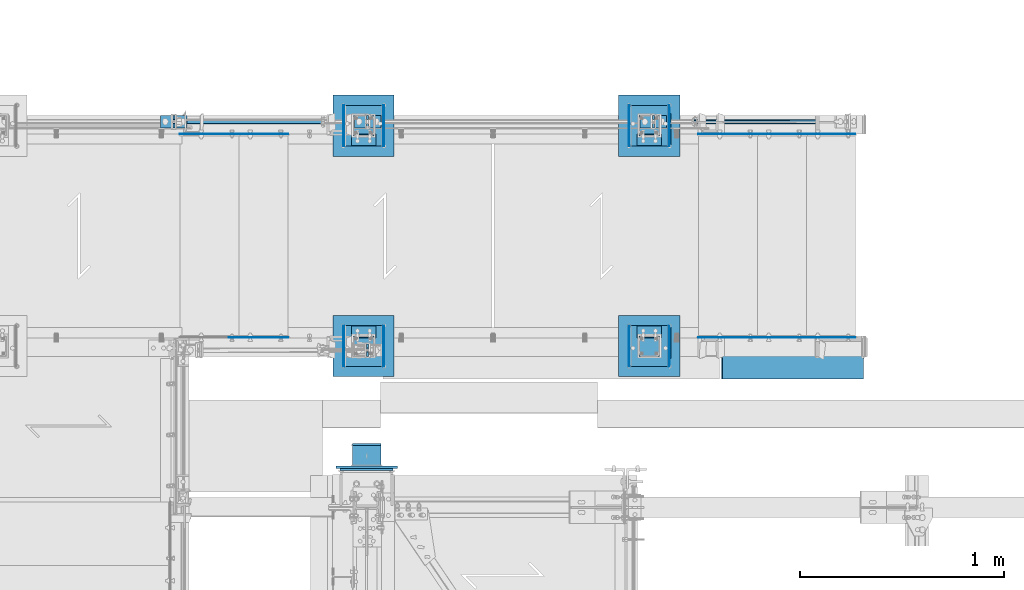
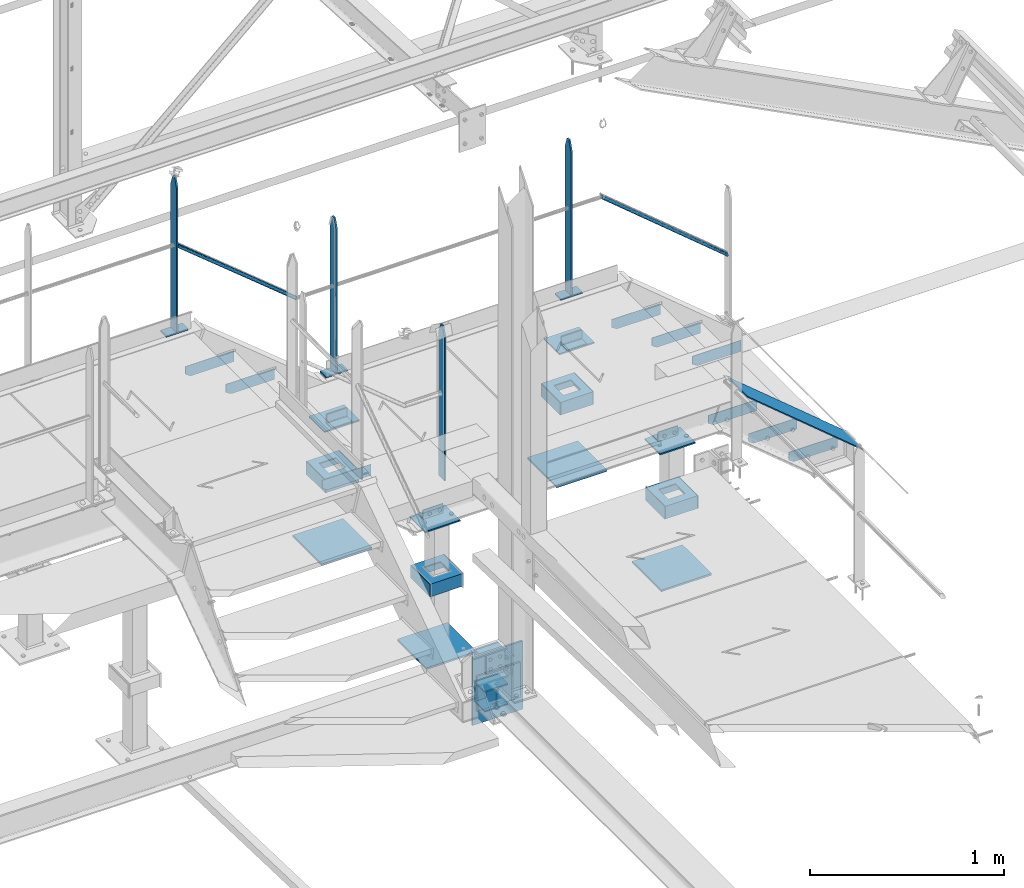
# One storey, part 98 of 496: 46 beams, 3 members, 18 elements without a shape of their own.
"""IFC2X3 building model written with IfcOpenShell, lengths in millimetres."""

from ifc_helpers import new_model, si_unit, frame, origin_with_axes, origin_2d_with_axis, place, context, subcontext, project, spatial, polyline, rectangle, hollow_circle, i_section, l_section, u_section, outline, extrude, boolean, clip, halfspace, material, type_object, element, aggregate, save


model = new_model("IFC2X3")

# Units and contexts
model_context = context("Model", 3, precision=1e-05, world=origin_with_axes())
body_context = subcontext(model_context, "Body", "Model", "MODEL_VIEW")
ifc_project = project(units=[si_unit("LENGTHUNIT", "METRE", prefix="MILLI"), si_unit("AREAUNIT", "SQUARE_METRE"), si_unit("VOLUMEUNIT", "CUBIC_METRE"), si_unit("MASSUNIT", "GRAM", prefix="KILO"), si_unit("TIMEUNIT", "SECOND"), si_unit("PLANEANGLEUNIT", "RADIAN"), si_unit("SOLIDANGLEUNIT", "STERADIAN"), si_unit("THERMODYNAMICTEMPERATUREUNIT", "DEGREE_CELSIUS"), si_unit("LUMINOUSINTENSITYUNIT", "LUMEN")], contexts=[model_context])

# Site, building, storey
site_placement = place(None, origin_with_axes())
site = spatial("IfcSite", under=ifc_project, at=site_placement, CompositionType="ELEMENT")
building_placement = place(site_placement, origin_with_axes())
building = spatial("IfcBuilding", under=site, at=building_placement, Name="Undefined", CompositionType="ELEMENT")
storey_placement = place(building_placement, origin_with_axes())
storey = spatial("IfcBuildingStorey", under=building, at=storey_placement, Name="Undefined", CompositionType="ELEMENT", Elevation=0.0)

# Assembly, member
assembly_1_placement = place(storey_placement, origin_with_axes())
assembly_1 = element("IfcElementAssembly", 1, at=assembly_1_placement, inside=storey, Name="VIDE", AssemblyPlace="NOTDEFINED", PredefinedType="NOTDEFINED")
ifc_material_1 = material(Name="Undefined/S235-E24")
member_type_1 = type_object("IfcMemberType", PredefinedType="NOTDEFINED")
member_1_placement = place(assembly_1_placement, frame((25902.16080149, 15929.9998774163, 7532.9377228811), z_axis=(0.0, -1.0, 0.0), x_axis=(-0.768221279597376, 0.0, 0.640184399664479)))
member_1 = element("IfcMember", 2, at=member_1_placement, type_object=member_type_1, material=ifc_material_1, Name="VIDE", context=body_context, shape_type="SweptSolid", body=[
    extrude(rectangle(XDim=6.0, YDim=200.0, at=origin_2d_with_axis()), frame((900.000000001432, 9.99200722164227e-14, 0.0), z_axis=(-1.0, 0.0, 0.0), x_axis=(0.0, -1.0, 0.0)), (0.0, 0.0, 1.0), 900.0),
])
aggregate(assembly_1, [member_1])

# Assembly, beam
assembly_2_placement = place(storey_placement, origin_with_axes())
assembly_2 = element("IfcElementAssembly", 3, at=assembly_2_placement, inside=storey, Name="MAIN COURANTE", AssemblyPlace="NOTDEFINED", PredefinedType="NOTDEFINED")
beam_type_1 = type_object("IfcBeamType", PredefinedType="NOTDEFINED")
beam_1_placement = place(assembly_2_placement, frame((23475.0061849194, 15970.0000882977, 9087.59993922658), z_axis=(0.0, 1.0, 0.0), x_axis=(0.0, 0.0, -1.0)))
beam_1 = element("IfcBeam", 4, at=beam_1_placement, type_object=beam_type_1, material=ifc_material_1, Name="MONTANT", context=body_context, shape_type="Clipping", body=[
    clip(clip(extrude(rectangle(XDim=10.0, YDim=60.0, at=origin_2d_with_axis()), frame((967.59999845988, 0.0, 0.0), z_axis=(-1.0, 0.0, 0.0), x_axis=(0.0, -1.0, 0.0)), (0.0, 0.0, 1.0), 967.6), halfspace(frame((-120.0, -5.0, -30.0), z_axis=(-0.316227766016838, 0.0, 0.948683298050514), x_axis=(0.0, 1.0, 0.0)), False)), halfspace(frame((60.0, -5.0, -30.0), z_axis=(-0.316227766016838, 0.0, -0.948683298050514), x_axis=(0.0, 1.0, 0.0)), False)),
])
aggregate(assembly_2, [beam_1])

# Assembly, beams, members
assembly_3_placement = place(storey_placement, origin_with_axes())
assembly_3 = element("IfcElementAssembly", 5, at=assembly_3_placement, inside=storey, Name="MAIN COURANTE", AssemblyPlace="NOTDEFINED", PredefinedType="NOTDEFINED")
beam_2_placement = place(assembly_3_placement, frame((24940.0061849193, 17089.9938659712, 8114.9999407569), z_axis=(0.0, 1.0, 0.0), x_axis=(-1.0, 0.0, 0.0)))
beam_2 = element("IfcBeam", 6, at=beam_2_placement, type_object=beam_type_1, material=ifc_material_1, context=body_context, shape_type="SweptSolid", body=[
    extrude(rectangle(XDim=10.0, YDim=60.0, at=origin_2d_with_axis()), frame((130.0, 0.0, 0.0), z_axis=(-1.0, 0.0, 0.0), x_axis=(0.0, -1.0, 0.0)), (0.0, 0.0, 1.0), 130.0),
])
beam_3_placement = place(assembly_3_placement, frame((23540.0061849193, 17089.9938659712, 8114.9999407569), z_axis=(0.0, 1.0, 0.0), x_axis=(-1.0, 0.0, 0.0)))
beam_3 = element("IfcBeam", 7, at=beam_3_placement, type_object=beam_type_1, material=ifc_material_1, context=body_context, shape_type="SweptSolid", body=[
    extrude(rectangle(XDim=10.0, YDim=60.0, at=origin_2d_with_axis()), frame((130.0, 0.0, 0.0), z_axis=(-1.0, 0.0, 0.0), x_axis=(0.0, -1.0, 0.0)), (0.0, 0.0, 1.0), 130.0),
])
beam_4_placement = place(assembly_3_placement, frame((22525.0061849193, 17089.9938659712, 9677.59999847), z_axis=(0.0, -1.0, 0.0), x_axis=(0.0, 0.0, -1.0)))
beam_4 = element("IfcBeam", 8, at=beam_4_placement, type_object=beam_type_1, material=ifc_material_1, Name="MONTANT", context=body_context, shape_type="Clipping", body=[
    clip(clip(extrude(rectangle(XDim=10.0, YDim=60.0, at=origin_2d_with_axis()), frame((967.59999845988, 0.0, 0.0), z_axis=(-1.0, 0.0, 0.0), x_axis=(0.0, -1.0, 0.0)), (0.0, 0.0, 1.0), 967.6), halfspace(frame((-120.0, 5.0, -30.0), z_axis=(-0.316227766016838, 0.0, 0.948683298050514), x_axis=(0.948683298050514, 0.0, 0.316227766016838)), False)), halfspace(frame((60.0, 5.0, -30.0), z_axis=(-0.316227766016838, 0.0, -0.948683298050514), x_axis=(-0.948683298050514, 0.0, 0.316227766016838)), False)),
])
beam_5_placement = place(assembly_3_placement, frame((22590.0061849193, 17089.9938659712, 8705.00000001012), z_axis=(0.0, 1.0, 0.0), x_axis=(-1.0, 0.0, 0.0)))
beam_5 = element("IfcBeam", 9, at=beam_5_placement, type_object=beam_type_1, material=ifc_material_1, context=body_context, shape_type="SweptSolid", body=[
    extrude(rectangle(XDim=10.0, YDim=60.0, at=origin_2d_with_axis()), frame((130.0, 0.0, 0.0), z_axis=(-1.0, 0.0, 0.0), x_axis=(0.0, -1.0, 0.0)), (0.0, 0.0, 1.0), 130.0),
])
beam_6_placement = place(assembly_3_placement, frame((24875.0061849193, 17089.9938659712, 9087.59993922658), z_axis=(0.0, -1.0, 0.0), x_axis=(0.0, 0.0, -1.0)))
beam_6 = element("IfcBeam", 10, at=beam_6_placement, type_object=beam_type_1, material=ifc_material_1, Name="MONTANT", context=body_context, shape_type="Clipping", body=[
    clip(clip(extrude(rectangle(XDim=10.0, YDim=60.0, at=origin_2d_with_axis()), frame((967.599939226584, 0.0, 0.0), z_axis=(-1.0, 0.0, 0.0), x_axis=(0.0, -1.0, 0.0)), (0.0, 0.0, 1.0), 967.6), halfspace(frame((-120.0, 5.0, -30.0), z_axis=(-0.316227766016838, 0.0, 0.948683298050514), x_axis=(0.948683298050514, 0.0, 0.316227766016838)), False)), halfspace(frame((60.0, 5.0, -30.0), z_axis=(-0.316227766016838, 0.0, -0.948683298050514), x_axis=(-0.948683298050514, 0.0, 0.316227766016838)), False)),
])
beam_7_placement = place(assembly_3_placement, frame((23475.0061849193, 17089.9938659712, 9087.59993922658), z_axis=(0.0, -1.0, 0.0), x_axis=(0.0, 0.0, -1.0)))
beam_7 = element("IfcBeam", 11, at=beam_7_placement, type_object=beam_type_1, material=ifc_material_1, Name="MONTANT", context=body_context, shape_type="Clipping", body=[
    clip(clip(extrude(rectangle(XDim=10.0, YDim=60.0, at=origin_2d_with_axis()), frame((967.59999845988, 0.0, 0.0), z_axis=(-1.0, 0.0, 0.0), x_axis=(0.0, -1.0, 0.0)), (0.0, 0.0, 1.0), 967.6), halfspace(frame((-120.0, 5.0, -30.0), z_axis=(-0.316227766016838, 0.0, 0.948683298050514), x_axis=(0.948683298050514, 0.0, 0.316227766016838)), False)), halfspace(frame((60.0, 5.0, -30.0), z_axis=(-0.316227766016838, 0.0, -0.948683298050514), x_axis=(-0.948683298050514, 0.0, 0.316227766016838)), False)),
])
member_type_2 = type_object("IfcMemberType", PredefinedType="NOTDEFINED")
member_2_placement = place(assembly_3_placement, frame((23250.3145397259, 17089.9898795537, 8653.80000001012), z_axis=(0.0, -1.0, 0.0), x_axis=(-0.773488973625643, 0.0, 0.633809756693245)))
member_2 = element("IfcMember", 12, at=member_2_placement, type_object=member_type_2, material=ifc_material_1, Name="LISSE", context=body_context, shape_type="Clipping", body=[
    clip(clip(extrude(hollow_circle(Radius=10.64999962, WallThickness=2.0, at=origin_2d_with_axis()), frame((949.850840245523, 0.0, 0.0), z_axis=(-1.0, 0.0, 0.0), x_axis=(0.0, -1.0, 0.0)), (0.0, 0.0, 1.0), 968.46), halfspace(frame((942.913936082841, -14.2395691075362, -0.00398641746141948), z_axis=(-0.773488973625642, -0.633809756693246, 0.0), x_axis=(0.0, 0.0, -1.0)), True)), halfspace(frame((3.80609846935477, -10.6499996200037, -0.00398641746141948), z_axis=(-0.941671114042507, -0.336534564313897, 0.0), x_axis=(0.0, 0.0, -1.0)), False)),
])
member_3_placement = place(assembly_3_placement, frame((25825.0061849193, 17089.9898795518, 8025.73196061016), z_axis=(0.0, -1.0, 0.0), x_axis=(-0.768221279597376, 0.0, 0.640184399664479)))
member_3 = element("IfcMember", 13, at=member_3_placement, type_object=member_type_2, material=ifc_material_1, Name="LISSE", context=body_context, shape_type="Clipping", body=[
    clip(clip(extrude(hollow_circle(Radius=10.64999962, WallThickness=2.0, at=origin_2d_with_axis()), frame((999.915375119574, 0.0, 0.0), z_axis=(-1.0, 0.0, 0.0), x_axis=(0.0, -1.0, 0.0)), (0.0, 0.0, 1.0), 1012.25), halfspace(frame((981.073731210257, -1.82259100256488e-07, -0.0039864193968242), z_axis=(-0.940271591821765, -0.340425224701349, 0.0), x_axis=(0.0, 0.0, -1.0)), True)), halfspace(frame((18.5934348061346, -14.5018748797629, -0.0039864193968242), z_axis=(-0.768221329187549, -0.640184340156267, 0.0), x_axis=(0.0, 0.0, -1.0)), False)),
])
aggregate(assembly_3, [beam_2, beam_3, beam_4, beam_5, member_2, member_3, beam_6, beam_7])

# Assembly, beam
assembly_4_placement = place(storey_placement, origin_with_axes())
assembly_4 = element("IfcElementAssembly", 14, at=assembly_4_placement, inside=storey, AssemblyPlace="NOTDEFINED", PredefinedType="NOTDEFINED")
beam_type_2 = type_object("IfcBeamType", PredefinedType="NOTDEFINED")
beam_8_placement = place(assembly_4_placement, frame((23605.0, 15840.0001225752, 7056.0), z_axis=(0.0, 0.0, -1.0), x_axis=(-1.0, 0.0, 0.0)))
beam_8 = element("IfcBeam", 15, at=beam_8_placement, type_object=beam_type_2, material=ifc_material_1, context=body_context, shape_type="SweptSolid", body=[
    extrude(outline(polyline([(0.0, 0.0), (300.0, 0.0), (300.0, 300.0), (0.0, 300.0), (0.0, 0.0)])), frame((0.0, 0.0, -6.0), z_axis=(0.0, 0.0, 1.0), x_axis=(1.0, 0.0, 0.0)), (0.0, 0.0, 1.0), 12.0),
])

assembly_5_placement = place(storey_placement, origin_with_axes())
assembly_5 = element("IfcElementAssembly", 16, at=assembly_5_placement, inside=storey, AssemblyPlace="NOTDEFINED", PredefinedType="NOTDEFINED")
beam_9_placement = place(assembly_5_placement, frame((25005.0, 15840.0001225752, 7056.0), z_axis=(0.0, 0.0, -1.0), x_axis=(-1.0, 0.0, 0.0)))
beam_9 = element("IfcBeam", 17, at=beam_9_placement, type_object=beam_type_2, material=ifc_material_1, context=body_context, shape_type="SweptSolid", body=[
    extrude(outline(polyline([(0.0, 0.0), (300.0, 0.0), (300.0, 300.0), (0.0, 300.0), (0.0, 0.0)])), frame((0.0, 0.0, -6.0), z_axis=(0.0, 0.0, 1.0), x_axis=(1.0, 0.0, 0.0)), (0.0, 0.0, 1.0), 12.0),
])

assembly_6_placement = place(storey_placement, origin_with_axes())
assembly_6 = element("IfcElementAssembly", 18, at=assembly_6_placement, inside=storey, AssemblyPlace="NOTDEFINED", PredefinedType="NOTDEFINED")
beam_10_placement = place(assembly_6_placement, frame((23605.0, 17219.9998774248, 7056.0), z_axis=(0.0, 0.0, 1.0), x_axis=(-1.0, 0.0, 0.0)))
beam_10 = element("IfcBeam", 19, at=beam_10_placement, type_object=beam_type_2, material=ifc_material_1, context=body_context, shape_type="SweptSolid", body=[
    extrude(outline(polyline([(0.0, 0.0), (300.0, 0.0), (300.0, 300.0), (0.0, 300.0), (0.0, 0.0)])), frame((0.0, 0.0, -6.0), z_axis=(0.0, 0.0, 1.0), x_axis=(1.0, 0.0, 0.0)), (0.0, 0.0, 1.0), 12.0),
])

assembly_7_placement = place(storey_placement, origin_with_axes())
assembly_7 = element("IfcElementAssembly", 20, at=assembly_7_placement, inside=storey, AssemblyPlace="NOTDEFINED", PredefinedType="NOTDEFINED")
beam_11_placement = place(assembly_7_placement, frame((25005.0, 17219.9998774248, 7056.0), z_axis=(0.0, 0.0, 1.0), x_axis=(-1.0, 0.0, 0.0)))
beam_11 = element("IfcBeam", 21, at=beam_11_placement, type_object=beam_type_2, material=ifc_material_1, context=body_context, shape_type="SweptSolid", body=[
    extrude(outline(polyline([(0.0, 0.0), (300.0, 0.0), (300.0, 300.0), (0.0, 300.0), (0.0, 0.0)])), frame((0.0, 0.0, -6.0), z_axis=(0.0, 0.0, 1.0), x_axis=(1.0, 0.0, 0.0)), (0.0, 0.0, 1.0), 12.0),
])

assembly_8_placement = place(storey_placement, origin_with_axes())
assembly_8 = element("IfcElementAssembly", 22, at=assembly_8_placement, inside=storey, AssemblyPlace="NOTDEFINED", PredefinedType="NOTDEFINED")
beam_12_placement = place(assembly_8_placement, frame((23470.0000000013, 15395.9999998722, 7394.99830350895), z_axis=(-1.0, 0.0, 0.0), x_axis=(0.0, 0.0, -1.0)))
beam_12 = element("IfcBeam", 23, at=beam_12_placement, type_object=beam_type_2, material=ifc_material_1, context=body_context, shape_type="SweptSolid", body=[
    extrude(rectangle(XDim=12.0, YDim=300.0, at=origin_2d_with_axis()), frame((429.999999999754, 0.0, 0.0), z_axis=(-1.0, 0.0, 0.0), x_axis=(0.0, -1.0, 0.0)), (0.0, 0.0, 1.0), 430.0),
])

# Beam
beam_type_3 = type_object("IfcBeamType", PredefinedType="NOTDEFINED")
beam_13_placement = place(assembly_4_placement, frame((23560.0, 15930.0006414961, 7846.00001160755), z_axis=(0.0, 0.0, -1.0), x_axis=(-1.0, 0.0, 0.0)))
beam_13 = element("IfcBeam", 24, at=beam_13_placement, type_object=beam_type_3, material=ifc_material_1, context=body_context, shape_type="SweptSolid", body=[
    extrude(outline(polyline([(0.0, 0.0), (210.0, 0.0), (210.0, 159.999481201172), (0.0, 159.999481201172), (0.0, 0.0)])), frame((0.0, 0.0, -4.0), z_axis=(0.0, 0.0, 1.0), x_axis=(1.0, 0.0, 0.0)), (0.0, 0.0, 1.0), 8.0),
])

beam_14_placement = place(assembly_5_placement, frame((24960.0, 15930.0006414961, 7846.00001160755), z_axis=(0.0, 0.0, -1.0), x_axis=(-1.0, 0.0, 0.0)))
beam_14 = element("IfcBeam", 25, at=beam_14_placement, type_object=beam_type_3, material=ifc_material_1, context=body_context, shape_type="SweptSolid", body=[
    extrude(outline(polyline([(0.0, 0.0), (210.0, 0.0), (210.0, 159.999481201172), (0.0, 159.999481201172), (0.0, 0.0)])), frame((0.0, 0.0, -4.0), z_axis=(0.0, 0.0, 1.0), x_axis=(1.0, 0.0, 0.0)), (0.0, 0.0, 1.0), 8.0),
])

beam_15_placement = place(assembly_6_placement, frame((23560.0, 17129.9993585039, 7846.00001160755), z_axis=(0.0, 0.0, 1.0), x_axis=(-1.0, 0.0, 0.0)))
beam_15 = element("IfcBeam", 26, at=beam_15_placement, type_object=beam_type_3, material=ifc_material_1, context=body_context, shape_type="SweptSolid", body=[
    extrude(outline(polyline([(0.0, 0.0), (210.0, 0.0), (210.0, 159.999481201172), (0.0, 159.999481201172), (0.0, 0.0)])), frame((0.0, 0.0, -4.0), z_axis=(0.0, 0.0, 1.0), x_axis=(1.0, 0.0, 0.0)), (0.0, 0.0, 1.0), 8.0),
])

beam_16_placement = place(assembly_7_placement, frame((24960.0, 17129.9993585039, 7846.00001160755), z_axis=(0.0, 0.0, 1.0), x_axis=(-1.0, 0.0, 0.0)))
beam_16 = element("IfcBeam", 27, at=beam_16_placement, type_object=beam_type_3, material=ifc_material_1, context=body_context, shape_type="SweptSolid", body=[
    extrude(outline(polyline([(0.0, 0.0), (210.0, 0.0), (210.0, 159.999481201172), (0.0, 159.999481201172), (0.0, 0.0)])), frame((0.0, 0.0, -4.0), z_axis=(0.0, 0.0, 1.0), x_axis=(1.0, 0.0, 0.0)), (0.0, 0.0, 1.0), 8.0),
])

beam_type_4 = type_object("IfcBeamType", PredefinedType="NOTDEFINED")
beam_17_placement = place(assembly_4_placement, frame((23553.0, 16090.0001225752, 7500.0), z_axis=(0.0, 0.0, 1.0), x_axis=(0.0, -1.0, 0.0)))
beam_17 = element("IfcBeam", 28, at=beam_17_placement, type_object=beam_type_4, material=ifc_material_1, Name="BORD", context=body_context, shape_type="SweptSolid", body=[
    extrude(rectangle(XDim=4.0, YDim=80.0, at=origin_2d_with_axis()), frame((200.0, 0.0, 0.0), z_axis=(-1.0, 0.0, 0.0), x_axis=(0.0, -1.0, 0.0)), (0.0, 0.0, 1.0), 200.0),
])

beam_18_placement = place(assembly_5_placement, frame((24953.0, 16090.0001225752, 7500.0), z_axis=(0.0, 0.0, 1.0), x_axis=(0.0, -1.0, 0.0)))
beam_18 = element("IfcBeam", 29, at=beam_18_placement, type_object=beam_type_4, material=ifc_material_1, Name="BORD", context=body_context, shape_type="SweptSolid", body=[
    extrude(rectangle(XDim=4.0, YDim=80.0, at=origin_2d_with_axis()), frame((200.0, 0.0, 0.0), z_axis=(-1.0, 0.0, 0.0), x_axis=(0.0, -1.0, 0.0)), (0.0, 0.0, 1.0), 200.0),
])

beam_19_placement = place(assembly_4_placement, frame((23357.0, 16090.0001225752, 7500.0), z_axis=(0.0, 0.0, 1.0), x_axis=(0.0, -1.0, 0.0)))
beam_19 = element("IfcBeam", 30, at=beam_19_placement, type_object=beam_type_4, material=ifc_material_1, Name="BORD", context=body_context, shape_type="SweptSolid", body=[
    extrude(rectangle(XDim=4.0, YDim=80.0, at=origin_2d_with_axis()), frame((200.0, 0.0, 0.0), z_axis=(-1.0, 0.0, 0.0), x_axis=(0.0, -1.0, 0.0)), (0.0, 0.0, 1.0), 200.0),
])

beam_20_placement = place(assembly_5_placement, frame((24757.0, 16090.0001225752, 7500.0), z_axis=(0.0, 0.0, 1.0), x_axis=(0.0, -1.0, 0.0)))
beam_20 = element("IfcBeam", 31, at=beam_20_placement, type_object=beam_type_4, material=ifc_material_1, Name="BORD", context=body_context, shape_type="SweptSolid", body=[
    extrude(rectangle(XDim=4.0, YDim=80.0, at=origin_2d_with_axis()), frame((200.0, 0.0, 0.0), z_axis=(-1.0, 0.0, 0.0), x_axis=(0.0, -1.0, 0.0)), (0.0, 0.0, 1.0), 200.0),
])

beam_21_placement = place(assembly_6_placement, frame((23553.0, 16969.9998774248, 7500.0), z_axis=(0.0, 0.0, 1.0), x_axis=(0.0, 1.0, 0.0)))
beam_21 = element("IfcBeam", 32, at=beam_21_placement, type_object=beam_type_4, material=ifc_material_1, Name="BORD", context=body_context, shape_type="SweptSolid", body=[
    extrude(rectangle(XDim=4.0, YDim=80.0, at=origin_2d_with_axis()), frame((200.0, 0.0, 0.0), z_axis=(-1.0, 0.0, 0.0), x_axis=(0.0, -1.0, 0.0)), (0.0, 0.0, 1.0), 200.0),
])

beam_22_placement = place(assembly_7_placement, frame((24953.0, 16969.9998774248, 7500.0), z_axis=(0.0, 0.0, 1.0), x_axis=(0.0, 1.0, 0.0)))
beam_22 = element("IfcBeam", 33, at=beam_22_placement, type_object=beam_type_4, material=ifc_material_1, Name="BORD", context=body_context, shape_type="SweptSolid", body=[
    extrude(rectangle(XDim=4.0, YDim=80.0, at=origin_2d_with_axis()), frame((200.0, 0.0, 0.0), z_axis=(-1.0, 0.0, 0.0), x_axis=(0.0, -1.0, 0.0)), (0.0, 0.0, 1.0), 200.0),
])

beam_23_placement = place(assembly_6_placement, frame((23357.0, 16969.9998774248, 7500.0), z_axis=(0.0, 0.0, 1.0), x_axis=(0.0, 1.0, 0.0)))
beam_23 = element("IfcBeam", 34, at=beam_23_placement, type_object=beam_type_4, material=ifc_material_1, Name="BORD", context=body_context, shape_type="SweptSolid", body=[
    extrude(rectangle(XDim=4.0, YDim=80.0, at=origin_2d_with_axis()), frame((200.0, 0.0, 0.0), z_axis=(-1.0, 0.0, 0.0), x_axis=(0.0, -1.0, 0.0)), (0.0, 0.0, 1.0), 200.0),
])

beam_24_placement = place(assembly_7_placement, frame((24757.0, 16969.9998774248, 7500.0), z_axis=(0.0, 0.0, 1.0), x_axis=(0.0, 1.0, 0.0)))
beam_24 = element("IfcBeam", 35, at=beam_24_placement, type_object=beam_type_4, material=ifc_material_1, Name="BORD", context=body_context, shape_type="SweptSolid", body=[
    extrude(rectangle(XDim=4.0, YDim=80.0, at=origin_2d_with_axis()), frame((200.0, 0.0, 0.0), z_axis=(-1.0, 0.0, 0.0), x_axis=(0.0, -1.0, 0.0)), (0.0, 0.0, 1.0), 200.0),
])

beam_type_5 = type_object("IfcBeamType", PredefinedType="NOTDEFINED")
beam_25_placement = place(assembly_4_placement, frame((23551.0, 15990.0001225752, 7500.0), z_axis=(0.0, 1.0, 0.0), x_axis=(-1.0, 0.0, 0.0)))
beam_25 = element("IfcBeam", 36, at=beam_25_placement, type_object=beam_type_5, material=ifc_material_1, context=body_context, shape_type="CSG", body=[
    boolean("DIFFERENCE", extrude(u_section(Depth=200.0, FlangeWidth=80.0, WebThickness=4.0, FlangeThickness=4.0, at=origin_2d_with_axis()), frame((192.0, 0.0, 0.0), z_axis=(-1.0, 0.0, 0.0), x_axis=(0.0, -1.0, 0.0)), (0.0, 0.0, 1.0), 192.0), extrude(outline(polyline([(0.0, 0.0), (101.0, 0.0), (101.0, 101.0), (0.0, 101.0), (0.0, 0.0)])), frame((146.5, -42.5, 50.5), z_axis=(0.0, 1.0, 0.0), x_axis=(0.0, 0.0, -1.0)), (0.0, 0.0, 1.0), 85.0)),
])

aggregate(assembly_4, [beam_13, beam_17, beam_19, beam_25, beam_8])

beam_26_placement = place(assembly_5_placement, frame((24951.0, 15990.0001225752, 7500.0), z_axis=(0.0, 1.0, 0.0), x_axis=(-1.0, 0.0, 0.0)))
beam_26 = element("IfcBeam", 37, at=beam_26_placement, type_object=beam_type_5, material=ifc_material_1, context=body_context, shape_type="CSG", body=[
    boolean("DIFFERENCE", extrude(u_section(Depth=200.0, FlangeWidth=80.0, WebThickness=4.0, FlangeThickness=4.0, at=origin_2d_with_axis()), frame((192.0, 0.0, 0.0), z_axis=(-1.0, 0.0, 0.0), x_axis=(0.0, -1.0, 0.0)), (0.0, 0.0, 1.0), 192.0), extrude(outline(polyline([(0.0, 0.0), (101.0, 0.0), (101.0, 101.0), (0.0, 101.0), (0.0, 0.0)])), frame((146.5, -42.5, 50.5), z_axis=(0.0, 1.0, 0.0), x_axis=(0.0, 0.0, -1.0)), (0.0, 0.0, 1.0), 85.0)),
])

aggregate(assembly_5, [beam_18, beam_14, beam_20, beam_26, beam_9])

beam_27_placement = place(assembly_6_placement, frame((23359.0, 17069.9998774248, 7500.0), z_axis=(0.0, -1.0, 0.0), x_axis=(1.0, 0.0, 0.0)))
beam_27 = element("IfcBeam", 38, at=beam_27_placement, type_object=beam_type_5, material=ifc_material_1, context=body_context, shape_type="CSG", body=[
    boolean("DIFFERENCE", extrude(u_section(Depth=200.0, FlangeWidth=80.0, WebThickness=4.0, FlangeThickness=4.0, at=origin_2d_with_axis()), frame((192.0, 0.0, 0.0), z_axis=(-1.0, 0.0, 0.0), x_axis=(0.0, -1.0, 0.0)), (0.0, 0.0, 1.0), 192.0), extrude(outline(polyline([(0.0, 0.0), (101.0, 0.0), (101.0, 101.0), (0.0, 101.0), (0.0, 0.0)])), frame((45.5, -42.5, -50.5), z_axis=(0.0, 1.0, 0.0), x_axis=(0.0, 0.0, 1.0)), (0.0, 0.0, 1.0), 85.0)),
])

aggregate(assembly_6, [beam_15, beam_21, beam_23, beam_27, beam_10])

beam_28_placement = place(assembly_7_placement, frame((24759.0, 17069.9998774248, 7500.0), z_axis=(0.0, -1.0, 0.0), x_axis=(1.0, 0.0, 0.0)))
beam_28 = element("IfcBeam", 39, at=beam_28_placement, type_object=beam_type_5, material=ifc_material_1, context=body_context, shape_type="CSG", body=[
    boolean("DIFFERENCE", extrude(u_section(Depth=200.0, FlangeWidth=80.0, WebThickness=4.0, FlangeThickness=4.0, at=origin_2d_with_axis()), frame((192.0, 0.0, 0.0), z_axis=(-1.0, 0.0, 0.0), x_axis=(0.0, -1.0, 0.0)), (0.0, 0.0, 1.0), 192.0), extrude(outline(polyline([(0.0, 0.0), (101.0, 0.0), (101.0, 101.0), (0.0, 101.0), (0.0, 0.0)])), frame((45.5, -42.5, -50.5), z_axis=(0.0, 1.0, 0.0), x_axis=(0.0, 0.0, 1.0)), (0.0, 0.0, 1.0), 85.0)),
])

aggregate(assembly_7, [beam_22, beam_16, beam_24, beam_28, beam_11])

# Assembly, beam
assembly_9_placement = place(storey_placement, origin_with_axes())
assembly_9 = element("IfcElementAssembly", 40, at=assembly_9_placement, inside=storey, Name="MARCHE", AssemblyPlace="NOTDEFINED", PredefinedType="NOTDEFINED")
beam_type_6 = type_object("IfcBeamType", PredefinedType="NOTDEFINED")
beam_29_placement = place(assembly_9_placement, frame((22844.9999902344, 17028.5001225837, 8503.3299407569), z_axis=(0.0, 1.0, 0.0), x_axis=(0.0, 0.0, -1.0)))
beam_29 = element("IfcBeam", 41, at=beam_29_placement, type_object=beam_type_6, material=ifc_material_1, Name="PLAT MARCHE", context=body_context, shape_type="SweptSolid", body=[
    extrude(outline(polyline([(0.0, 0.0), (70.0, 0.0), (70.0, 260.0), (50.0, 290.0), (0.0, 290.0), (0.0, 0.0)])), frame((0.0, 0.0, -1.5), z_axis=(0.0, 0.0, 1.0), x_axis=(1.0, 0.0, 0.0)), (0.0, 0.0, 1.0), 3.0),
])
aggregate(assembly_9, [beam_29])

# Assembly, beams
assembly_10_placement = place(storey_placement, origin_with_axes())
assembly_10 = element("IfcElementAssembly", 42, at=assembly_10_placement, inside=storey, Name="MARCHE", AssemblyPlace="NOTDEFINED", PredefinedType="NOTDEFINED")
beam_30_placement = place(assembly_10_placement, frame((23084.9999902344, 17028.5001225837, 8306.6699407569), z_axis=(0.0, 1.0, 0.0), x_axis=(0.0, 0.0, -1.0)))
beam_30 = element("IfcBeam", 43, at=beam_30_placement, type_object=beam_type_6, material=ifc_material_1, Name="PLAT MARCHE", context=body_context, shape_type="SweptSolid", body=[
    extrude(outline(polyline([(0.0, 0.0), (70.0, 0.0), (70.0, 260.0), (50.0, 290.0), (0.0, 290.0), (0.0, 0.0)])), frame((0.0, 0.0, -1.5), z_axis=(0.0, 0.0, 1.0), x_axis=(1.0, 0.0, 0.0)), (0.0, 0.0, 1.0), 3.0),
])
beam_31_placement = place(assembly_10_placement, frame((23084.9999902344, 16031.4998774163, 8306.6699407569), z_axis=(0.0, 1.0, 0.0), x_axis=(0.0, 0.0, -1.0)))
beam_31 = element("IfcBeam", 44, at=beam_31_placement, type_object=beam_type_6, material=ifc_material_1, Name="PLAT MARCHE", context=body_context, shape_type="SweptSolid", body=[
    extrude(outline(polyline([(0.0, 0.0), (70.0, 0.0), (70.0, 260.0), (50.0, 290.0), (0.0, 290.0), (0.0, 0.0)])), frame((0.0, 0.0, -1.5), z_axis=(0.0, 0.0, 1.0), x_axis=(1.0, 0.0, 0.0)), (0.0, 0.0, 1.0), 3.0),
])
aggregate(assembly_10, [beam_30, beam_31])

assembly_11_placement = place(storey_placement, origin_with_axes())
assembly_11 = element("IfcElementAssembly", 45, at=assembly_11_placement, inside=storey, Name="MARCHE", AssemblyPlace="NOTDEFINED", PredefinedType="NOTDEFINED")
beam_32_placement = place(assembly_11_placement, frame((25384.9999902344, 17028.5001225837, 7909.9999407569), z_axis=(0.0, 1.0, 0.0), x_axis=(0.0, 0.0, -1.0)))
beam_32 = element("IfcBeam", 46, at=beam_32_placement, type_object=beam_type_6, material=ifc_material_1, Name="PLAT MARCHE", context=body_context, shape_type="SweptSolid", body=[
    extrude(outline(polyline([(0.0, 0.0), (70.0, 0.0), (70.0, 260.0), (50.0, 290.0), (0.0, 290.0), (0.0, 0.0)])), frame((0.0, 0.0, -1.5), z_axis=(0.0, 0.0, 1.0), x_axis=(1.0, 0.0, 0.0)), (0.0, 0.0, 1.0), 3.0),
])
beam_33_placement = place(assembly_11_placement, frame((25384.9999902344, 16031.4998774163, 7909.9999407569), z_axis=(0.0, 1.0, 0.0), x_axis=(0.0, 0.0, -1.0)))
beam_33 = element("IfcBeam", 47, at=beam_33_placement, type_object=beam_type_6, material=ifc_material_1, Name="PLAT MARCHE", context=body_context, shape_type="SweptSolid", body=[
    extrude(outline(polyline([(0.0, 0.0), (70.0, 0.0), (70.0, 260.0), (50.0, 290.0), (0.0, 290.0), (0.0, 0.0)])), frame((0.0, 0.0, -1.5), z_axis=(0.0, 0.0, 1.0), x_axis=(1.0, 0.0, 0.0)), (0.0, 0.0, 1.0), 3.0),
])
aggregate(assembly_11, [beam_32, beam_33])

assembly_12_placement = place(storey_placement, origin_with_axes())
assembly_12 = element("IfcElementAssembly", 48, at=assembly_12_placement, inside=storey, Name="MARCHE", AssemblyPlace="NOTDEFINED", PredefinedType="NOTDEFINED")
beam_34_placement = place(assembly_12_placement, frame((25624.9999902344, 17028.5001225837, 7710.0), z_axis=(0.0, 1.0, 0.0), x_axis=(0.0, 0.0, -1.0)))
beam_34 = element("IfcBeam", 49, at=beam_34_placement, type_object=beam_type_6, material=ifc_material_1, Name="PLAT MARCHE", context=body_context, shape_type="SweptSolid", body=[
    extrude(outline(polyline([(0.0, 0.0), (70.0, 0.0), (70.0, 260.0), (50.0, 290.0), (0.0, 290.0), (0.0, 0.0)])), frame((0.0, 0.0, -1.5), z_axis=(0.0, 0.0, 1.0), x_axis=(1.0, 0.0, 0.0)), (0.0, 0.0, 1.0), 3.0),
])
beam_35_placement = place(assembly_12_placement, frame((25624.9999902344, 16031.4998774163, 7710.0), z_axis=(0.0, 1.0, 0.0), x_axis=(0.0, 0.0, -1.0)))
beam_35 = element("IfcBeam", 50, at=beam_35_placement, type_object=beam_type_6, material=ifc_material_1, Name="PLAT MARCHE", context=body_context, shape_type="SweptSolid", body=[
    extrude(outline(polyline([(0.0, 0.0), (70.0, 0.0), (70.0, 260.0), (50.0, 290.0), (0.0, 290.0), (0.0, 0.0)])), frame((0.0, 0.0, -1.5), z_axis=(0.0, 0.0, 1.0), x_axis=(1.0, 0.0, 0.0)), (0.0, 0.0, 1.0), 3.0),
])
aggregate(assembly_12, [beam_34, beam_35])

assembly_13_placement = place(storey_placement, origin_with_axes())
assembly_13 = element("IfcElementAssembly", 51, at=assembly_13_placement, inside=storey, Name="MARCHE", AssemblyPlace="NOTDEFINED", PredefinedType="NOTDEFINED")
beam_36_placement = place(assembly_13_placement, frame((25864.9999902344, 17028.5001225837, 7510.0), z_axis=(0.0, 1.0, 0.0), x_axis=(0.0, 0.0, -1.0)))
beam_36 = element("IfcBeam", 52, at=beam_36_placement, type_object=beam_type_6, material=ifc_material_1, Name="PLAT MARCHE", context=body_context, shape_type="SweptSolid", body=[
    extrude(outline(polyline([(0.0, 0.0), (70.0, 0.0), (70.0, 260.0), (50.0, 290.0), (0.0, 290.0), (0.0, 0.0)])), frame((0.0, 0.0, -1.5), z_axis=(0.0, 0.0, 1.0), x_axis=(1.0, 0.0, 0.0)), (0.0, 0.0, 1.0), 3.0),
])
beam_37_placement = place(assembly_13_placement, frame((25864.9999902344, 16031.4998774163, 7510.0), z_axis=(0.0, 1.0, 0.0), x_axis=(0.0, 0.0, -1.0)))
beam_37 = element("IfcBeam", 53, at=beam_37_placement, type_object=beam_type_6, material=ifc_material_1, Name="PLAT MARCHE", context=body_context, shape_type="SweptSolid", body=[
    extrude(outline(polyline([(0.0, 0.0), (70.0, 0.0), (70.0, 260.0), (50.0, 290.0), (0.0, 290.0), (0.0, 0.0)])), frame((0.0, 0.0, -1.5), z_axis=(0.0, 0.0, 1.0), x_axis=(1.0, 0.0, 0.0)), (0.0, 0.0, 1.0), 3.0),
])
aggregate(assembly_13, [beam_36, beam_37])

# Assembly, beam
assembly_14_placement = place(storey_placement, origin_with_axes())
assembly_14 = element("IfcElementAssembly", 54, at=assembly_14_placement, inside=storey, AssemblyPlace="NOTDEFINED", PredefinedType="NOTDEFINED")
beam_type_7 = type_object("IfcBeamType", PredefinedType="NOTDEFINED")
beam_38_placement = place(assembly_14_placement, frame((23515.0, 16060.0001225625, 7879.9999407569), z_axis=(0.0, 0.0, 1.0), x_axis=(-1.0, 0.0, 0.0)))
beam_38 = element("IfcBeam", 55, at=beam_38_placement, type_object=beam_type_7, material=ifc_material_1, context=body_context, shape_type="SweptSolid", body=[
    extrude(l_section(Depth=60.0, Width=60.0, Thickness=6.0, FilletRadius=8.0, EdgeRadius=4.0, at=origin_2d_with_axis()), frame((120.0, 0.0, 0.0), z_axis=(-1.0, 0.0, 0.0), x_axis=(0.0, -1.0, 0.0)), (0.0, 0.0, 1.0), 120.0),
])
aggregate(assembly_14, [beam_38])

assembly_15_placement = place(storey_placement, origin_with_axes())
assembly_15 = element("IfcElementAssembly", 56, at=assembly_15_placement, inside=storey, AssemblyPlace="NOTDEFINED", PredefinedType="NOTDEFINED")
beam_39_placement = place(assembly_15_placement, frame((24915.0, 16060.0001225625, 7879.9999407569), z_axis=(0.0, 0.0, 1.0), x_axis=(-1.0, 0.0, 0.0)))
beam_39 = element("IfcBeam", 57, at=beam_39_placement, type_object=beam_type_7, material=ifc_material_1, context=body_context, shape_type="SweptSolid", body=[
    extrude(l_section(Depth=60.0, Width=60.0, Thickness=6.0, FilletRadius=8.0, EdgeRadius=4.0, at=origin_2d_with_axis()), frame((120.0, 0.0, 0.0), z_axis=(-1.0, 0.0, 0.0), x_axis=(0.0, -1.0, 0.0)), (0.0, 0.0, 1.0), 120.0),
])
aggregate(assembly_15, [beam_39])

assembly_16_placement = place(storey_placement, origin_with_axes())
assembly_16 = element("IfcElementAssembly", 58, at=assembly_16_placement, inside=storey, AssemblyPlace="NOTDEFINED", PredefinedType="NOTDEFINED")
beam_40_placement = place(assembly_16_placement, frame((23395.0, 16999.9998774375, 7879.9999407569), z_axis=(0.0, 0.0, 1.0), x_axis=(1.0, 0.0, 0.0)))
beam_40 = element("IfcBeam", 59, at=beam_40_placement, type_object=beam_type_7, material=ifc_material_1, context=body_context, shape_type="SweptSolid", body=[
    extrude(l_section(Depth=60.0, Width=60.0, Thickness=6.0, FilletRadius=8.0, EdgeRadius=4.0, at=origin_2d_with_axis()), frame((120.0, 0.0, 0.0), z_axis=(-1.0, 0.0, 0.0), x_axis=(0.0, -1.0, 0.0)), (0.0, 0.0, 1.0), 120.0),
])
aggregate(assembly_16, [beam_40])

assembly_17_placement = place(storey_placement, origin_with_axes())
assembly_17 = element("IfcElementAssembly", 60, at=assembly_17_placement, inside=storey, AssemblyPlace="NOTDEFINED", PredefinedType="NOTDEFINED")
beam_41_placement = place(assembly_17_placement, frame((24795.0, 16999.9998774375, 7879.9999407569), z_axis=(0.0, 0.0, 1.0), x_axis=(1.0, 0.0, 0.0)))
beam_41 = element("IfcBeam", 61, at=beam_41_placement, type_object=beam_type_7, material=ifc_material_1, context=body_context, shape_type="SweptSolid", body=[
    extrude(l_section(Depth=60.0, Width=60.0, Thickness=6.0, FilletRadius=8.0, EdgeRadius=4.0, at=origin_2d_with_axis()), frame((120.0, 0.0, 0.0), z_axis=(-1.0, 0.0, 0.0), x_axis=(0.0, -1.0, 0.0)), (0.0, 0.0, 1.0), 120.0),
])
aggregate(assembly_17, [beam_41])

# Beam
beam_type_8 = type_object("IfcBeamType", PredefinedType="NOTDEFINED")
beam_42_placement = place(assembly_8_placement, frame((23470.0000000043, 15506.9999999803, 7146.49830350798), z_axis=(-1.0, 0.0, 0.0), x_axis=(0.0, 0.0, -1.0)))
beam_42 = element("IfcBeam", 62, at=beam_42_placement, type_object=beam_type_8, material=ifc_material_1, Name="PLAT", context=body_context, shape_type="SweptSolid", body=[
    extrude(rectangle(XDim=10.0, YDim=140.0, at=origin_2d_with_axis()), frame((132.999999999945, 0.0, 0.0), z_axis=(-1.0, 0.0, 0.0), x_axis=(0.0, -1.0, 0.0)), (0.0, 0.0, 1.0), 133.0),
])

beam_43_placement = place(assembly_8_placement, frame((23470.0000000042, 15506.9999999545, 7346.49830350782), z_axis=(-1.0, 0.0, 0.0), x_axis=(0.0, 0.0, -1.0)))
beam_43 = element("IfcBeam", 63, at=beam_43_placement, type_object=beam_type_8, material=ifc_material_1, Name="PLAT", context=body_context, shape_type="SweptSolid", body=[
    extrude(rectangle(XDim=10.0, YDim=140.0, at=origin_2d_with_axis()), frame((132.999999999945, 0.0, 0.0), z_axis=(-1.0, 0.0, 0.0), x_axis=(0.0, -1.0, 0.0)), (0.0, 0.0, 1.0), 133.0),
])

ifc_material_2 = material(Name="Undefined/S275-E28")
beam_type_9 = type_object("IfcBeamType", Name="HEA140", PredefinedType="NOTDEFINED")
beam_44_placement = place(assembly_8_placement, frame((23470.0000000022, 15401.9999999801, 7079.99830350799), z_axis=(0.0, 0.0, 1.0), x_axis=(0.0, 1.0, 0.0)))
beam_44 = element("IfcBeam", 64, at=beam_44_placement, type_object=beam_type_9, material=ifc_material_2, ObjectType="HEA140", context=body_context, shape_type="SweptSolid", body=[
    extrude(i_section(OverallWidth=140.0, OverallDepth=133.0, WebThickness=5.5, FlangeThickness=8.5, FilletRadius=12.0, at=origin_2d_with_axis()), frame((100.000000000021, 5.72981662116945e-11, -4.09272615797818e-12), z_axis=(-1.0, 0.0, 0.0), x_axis=(0.0, -1.0, 0.0)), (0.0, 0.0, 1.0), 100.0),
])

beam_45_placement = place(assembly_8_placement, frame((23470.0000000021, 15401.9999999543, 7279.99830350785), z_axis=(0.0, 0.0, 1.0), x_axis=(0.0, 1.0, 0.0)))
beam_45 = element("IfcBeam", 65, at=beam_45_placement, type_object=beam_type_9, material=ifc_material_2, ObjectType="HEA140", context=body_context, shape_type="SweptSolid", body=[
    extrude(i_section(OverallWidth=140.0, OverallDepth=133.0, WebThickness=5.5, FlangeThickness=8.5, FilletRadius=12.0, at=origin_2d_with_axis()), frame((100.000000000021, 5.72981662116945e-11, -4.09272615797818e-12), z_axis=(-1.0, 0.0, 0.0), x_axis=(0.0, -1.0, 0.0)), (0.0, 0.0, 1.0), 100.0),
])

aggregate(assembly_8, [beam_42, beam_44, beam_43, beam_45, beam_12])

# Assembly, beam
assembly_18_placement = place(storey_placement, origin_with_axes())
assembly_18 = element("IfcElementAssembly", 66, at=assembly_18_placement, inside=storey, AssemblyPlace="NOTDEFINED", PredefinedType="NOTDEFINED")
beam_type_10 = type_object("IfcBeamType", PredefinedType="NOTDEFINED")
beam_46_placement = place(assembly_18_placement, frame((23469.9999999995, 15384.9999999539, 7273.9991406194), z_axis=(-1.0, 0.0, 0.0), x_axis=(0.0, 0.0, -1.0)))
beam_46 = element("IfcBeam", 67, at=beam_46_placement, type_object=beam_type_10, material=ifc_material_1, context=body_context, shape_type="SweptSolid", body=[
    extrude(rectangle(XDim=10.0, YDim=260.0, at=origin_2d_with_axis()), frame((220.000836427161, 0.0, 0.0), z_axis=(-1.0, 0.0, 0.0), x_axis=(0.0, -1.0, 0.0)), (0.0, 0.0, 1.0), 220.0),
])
aggregate(assembly_18, [beam_46])

save(model, "model.ifc")
